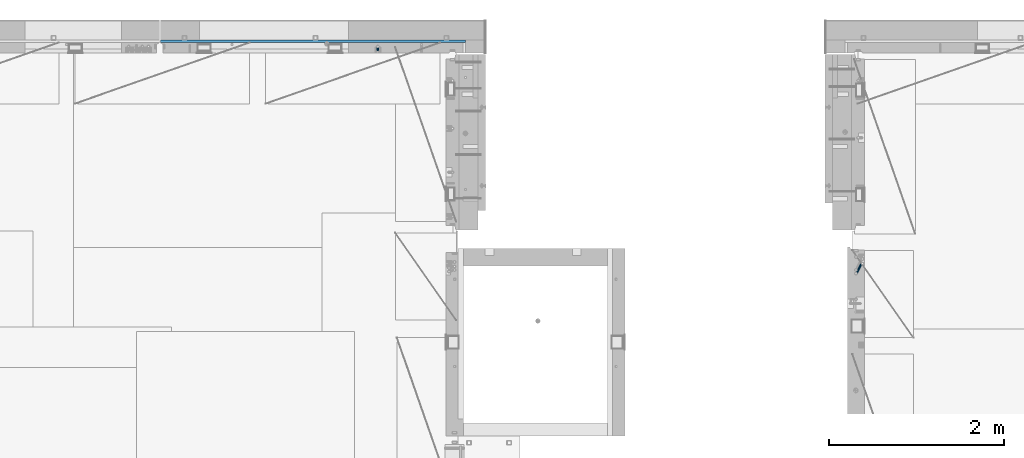
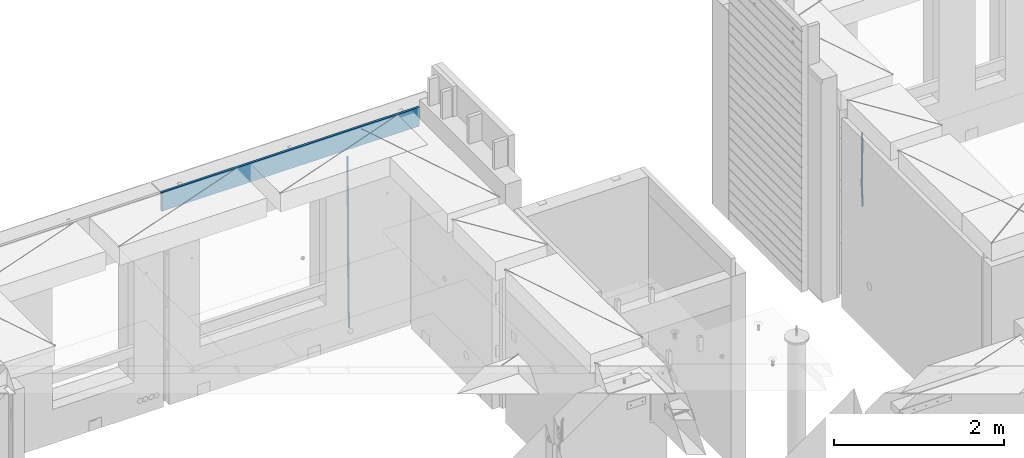
# One storey, part 105 of 309: 3 beams, 2 elements without a shape of their own.
"""IFC2X3 building model written with IfcOpenShell, lengths in millimetres."""

from ifc_helpers import new_model, si_unit, frame, origin_with_axes, place, context, subcontext, project, spatial, faceted_brep, material, type_object, element, aggregate, save


model = new_model("IFC2X3")

# Units and contexts
model_context = context("Model", 3, precision=1e-05, world=origin_with_axes())
body_context = subcontext(model_context, "Body", "Model", "MODEL_VIEW")
ifc_project = project(units=[si_unit("LENGTHUNIT", "METRE", prefix="MILLI"), si_unit("AREAUNIT", "SQUARE_METRE"), si_unit("VOLUMEUNIT", "CUBIC_METRE"), si_unit("MASSUNIT", "GRAM", prefix="KILO"), si_unit("TIMEUNIT", "SECOND"), si_unit("PLANEANGLEUNIT", "RADIAN"), si_unit("SOLIDANGLEUNIT", "STERADIAN"), si_unit("THERMODYNAMICTEMPERATUREUNIT", "DEGREE_CELSIUS"), si_unit("LUMINOUSINTENSITYUNIT", "LUMEN")], contexts=[model_context])

# Site, building, storey
site_placement = place(None, origin_with_axes())
site = spatial("IfcSite", under=ifc_project, at=site_placement, CompositionType="ELEMENT")
building_placement = place(site_placement, origin_with_axes())
building = spatial("IfcBuilding", under=site, at=building_placement, CompositionType="ELEMENT")
storey_placement = place(building_placement, origin_with_axes())
storey = spatial("IfcBuildingStorey", under=building, at=storey_placement, Name="7", CompositionType="ELEMENT", Elevation=0.0)

# Assembly, beam
assembly_1_placement = place(storey_placement, origin_with_axes())
assembly_1 = element("IfcElementAssembly", 1, at=assembly_1_placement, inside=storey, AssemblyPlace="NOTDEFINED", PredefinedType="REINFORCEMENT_UNIT")
ifc_material_1 = material()
beam_type_1 = type_object("IfcBeamType", Name="D20", PredefinedType="NOTDEFINED")
beam_1_placement = place(assembly_1_placement, frame((16830.0000000039, 22654.999995444, 99990.0), z_axis=(-0.000205762999925498, 0.999642804629538, -0.0267249099901004), x_axis=(4.30000201928125e-08, 0.0267249099948059, 0.999642825806181)))
beam_1 = element("IfcBeam", 2, at=beam_1_placement, type_object=beam_type_1, material=ifc_material_1, Name="JM20", ObjectType="D20", context=body_context, shape_type="Brep", body=[
    faceted_brep([(0.0, -10.0, 0.0), (-4.19531716033816e-08, -7.07106781186667, -7.07106781187031), (60.4266690400545, -7.0710677960451, -7.07106780570757), (60.4266690441291, -9.99999998418934, 6.15546014159918e-09), (0.0, 0.0, -10.0), (60.426669036824, 1.58106558956206e-08, -9.99999999384454), (4.196772351861e-08, 7.07106781186303, -7.07106781186667), (60.4266690363438, 7.07106782768096, -7.07106780570757), (0.0, 10.0, 0.0), (60.4266690388904, 10.0000000158179, 6.15182216279209e-09), (4.196772351861e-08, 7.07106781185939, 7.07106781185939), (60.4266690429649, 7.07106782768096, 7.07106781802577), (0.0, 0.0, 10.0), (60.4266690461809, 1.58179318532348e-08, 10.0000000061555), (-4.19531716033816e-08, -7.07106781187031, 7.07106781185939), (60.4266690466611, -7.07106779605238, 7.07106781802213), (61.0378400410118, -7.07106779588503, -7.07106780564936), (60.991799419251, -9.99999998403655, 6.21366780251265e-09), (61.0569027789461, 1.5985278878361e-08, -9.99999999378269), (61.0378209396877, 7.07106782784831, -7.07106780564936), (60.9917724058905, 10.0000000159635, 6.21366780251265e-09), (60.9457317841297, 7.07106782781193, 7.0710678180767), (60.9266690461809, 1.59488990902901e-08, 10.0000000062028), (60.9457508854539, -7.07106779591413, 7.0710678180767), (61.6489592143771, -7.07106614513759, -7.06310863441468), (61.5568818710308, -9.9999984576425, 0.00735959856683621), (61.6870830769039, 1.71821739058942e-06, -9.99179257185824), (61.6489210170112, 7.07106947854481, -7.06310888312146), (61.556827851804, 10.0000015422847, 0.00735924683976918), (61.4647505084577, 7.07106922979438, 7.07782747982128), (61.4266266459163, 1.36643211590126e-06, 10.0065114172685), (61.464788705809, -7.07106639389531, 7.07782772852806), (176.543135720174, -7.07075579406956, -5.56673531796696), (176.451058376813, -9.99968810657447, 1.50373291501455), (176.581259582701, 0.000312069292704109, -8.49541925541052), (176.543097522794, 7.07137982961285, -5.56673556667374), (176.451004357587, 10.00031189336, 1.50373256329476), (176.35892701424, 7.07137958085514, 8.57420079627263), (176.320803151699, 0.000311717507429421, 11.5028847337162), (176.358965211621, -7.07075604281999, 8.57420104497578), (177.098753836006, -7.07075429323595, -5.55949898843028), (176.98362511232, -9.99968666800123, 1.510669025065), (177.146421932586, 0.000313595905026887, -8.48805862247536), (177.098706077581, 7.07138133041735, -5.55949936166144), (176.983557571715, 10.0003133318824, 1.51066849724157), (176.868428848029, 7.07138095712435, 8.58083651073321), (176.820760751449, 0.000313067976094317, 11.5093961447819), (176.868476606425, -7.07075466652896, 8.58083688396073), (177.654312950661, -7.07075204110879, -5.54863964998367), (177.516135294456, -9.99968450931192, 1.52107783331303), (177.711524267797, 0.000315886711177882, -8.47701274570863), (177.654255632195, 7.07138358250813, -5.54864021007961), (177.516054233929, 10.0003154905207, 1.5210770412159), (177.377876577739, 7.0713830223176, 8.59079452451624), (177.320665260588, 0.000315094497636892, 11.5191676202448), (177.377933896176, -7.07075260129932, 8.59079508461218), (299.436796249574, -7.07025836271714, -3.1681962331204), (299.298618593355, -9.99919083092027, 3.90152125031091), (299.494007566798, 0.000809565110102994, -6.09656932889993), (299.436738931283, 7.07187726089978, -3.16819679320906), (299.298537533061, 10.0008091689197, 3.90152045822106), (299.160359876842, 7.07187670072017, 10.9712379416487), (299.103148559603, 0.000808772889286047, 13.8996110374392), (299.160417195119, -7.07025892290039, 10.9712385017483), (299.98743051647, -7.07025613056248, -3.15743315966392), (299.971788958996, -9.99918809853989, 3.91467979818117), (299.993912075952, 0.000811591617093654, -6.08679785393178), (299.987423933868, 7.07187949325817, -3.1574327280432), (299.971753863239, 10.0008119014747, 3.91467990454839), (299.95611230444, 7.07187992653053, 10.9867922621015), (299.949630744944, 0.000812204350950196, 13.9161569563694), (299.956118887014, -7.07025569729012, 10.9867918304735), (300.538107039494, -7.07025785017686, -3.16575821840888), (300.644985195438, -9.99919020432935, 3.90450175465594), (300.493854948218, 0.000810030429420294, -6.09435592770024), (300.538151196495, 7.071877773491, -3.16575855385963), (300.645047642858, 10.0008097955724, 3.90450128024895), (300.751925798773, 7.07187744142357, 10.9747612533101), (300.796177890064, 0.000809560813650023, 13.9033589625978), (300.751881641787, -7.07025818224065, 10.9747615887682), (2293.36490490142, -7.07648090940347, -33.2930642912361), (2293.47178305736, -10.0054132635523, -26.2228043181785), (2293.32065281013, -0.00541302880083094, -36.2216620005347), (2293.36494905842, 7.06565471425711, -33.2930646266868), (2293.47184550477, 9.99458673634581, -26.2228047925819), (2293.57872366071, 7.06565438219332, -19.1525448195243), (2293.62297575199, -0.00541349841296324, -16.2239471102366), (2293.57867950371, -7.0764812414709, -19.1525444840736), (2294.0658245362, -7.07648309818615, -33.3036607065333), (2294.05312277409, -10.0054150789219, -26.2315929392535), (2294.10928714235, -0.00541549149056664, -36.2335844756526), (2294.15805078732, 7.06565223761572, -33.3050546393533), (2294.18355038921, 9.99458451388637, -26.2335642579346), (2294.17084862708, 7.06565253314329, -19.1614964906439), (2294.12738602093, -0.00541507354500936, -16.2315727215355), (2294.07862237596, -7.07648280265857, -19.1601025578348), (2294.76670261032, -7.08562269121467, -33.294332712383), (2294.63442802057, -10.0129954178956, -26.2238563411993), (2294.89787471293, -0.0156988342423574, -36.2230891548279), (2294.95110548967, 7.05531064255774, -33.2944998654275), (2294.89521307347, 9.98530428734011, -26.2240927312887), (2294.76293848372, 7.0579315606592, -19.1536163601049), (2294.63176638114, -0.0119922963167483, -16.2248599176673), (2294.57853560438, -7.08300177311321, -19.1534492070678), (2316.52657204497, -7.36937582653991, -33.0047303660212), (2316.39429745522, -10.2967485532172, -25.9342539948302), (2316.65774414754, -0.299451969567599, -35.9334868084661), (2316.7109749243, 6.7715575072325, -33.0048975190657), (2316.65508250811, 9.70155115201487, -25.9344903849269), (2316.52280791836, 6.7741784253376, -18.8640140137468), (2316.39163581574, -0.295745431634714, -15.9352575713092), (2316.33840503903, -7.36675490843481, -18.863846860706), (2317.16202064224, -7.37766220584308, -32.9962731735213), (2317.05438744847, -10.3053562613532, -25.9254688497131), (2317.23607125619, -0.306993473008333, -35.925789846493), (2317.23316144495, 6.76474808850253, -32.9979477328052), (2317.15499573652, 9.6950321815566, -25.9278370341635), (2317.04736254275, 6.7673381260538, -18.8570327103698), (2316.97331192881, -0.303330606784584, -15.9275160373909), (2316.97622174003, -7.37507216829545, -18.8553581510787), (2317.79752306276, -7.37578610372293, -32.9880110666527), (2317.71453320107, -10.3033876998124, -25.9168792378296), (2317.81444760226, -0.305295583297266, -35.918287695793), (2317.75539265381, 6.76628640723357, -32.9911928173897), (2317.65495180529, 9.69652304524061, -25.9213789128698), (2317.5719619436, 6.76892144914746, -18.8502470840467), (2317.55503740412, -0.301569071270933, -15.9199704549137), (2317.61409235255, -7.3731510618054, -18.847065333317), (2417.8183084176, -7.07752398473531, -31.6906369377139), (2417.73531855589, -10.0051255808248, -24.6195051088798), (2417.83523295709, -0.007033464313281, -34.6209135668432), (2417.77617800863, 7.06454852621755, -31.6938186884508), (2417.67573716014, 9.99478516423187, -24.6240047839383), (2417.59274729842, 7.06718356813872, -17.5528729551006), (2417.57582275895, -0.00330695228694822, -14.6225963259749), (2417.6348777074, -7.07488894281778, -17.5496912043673)], [[[0, 1, 2, 3]], [[1, 4, 5, 2]], [[4, 6, 7, 5]], [[6, 8, 9, 7]], [[8, 10, 11, 9]], [[10, 12, 13, 11]], [[12, 14, 15, 13]], [[14, 0, 3, 15]], [[14, 12, 10, 8, 6, 4, 1, 0]], [[3, 2, 16, 17]], [[2, 5, 18, 16]], [[5, 7, 19, 18]], [[7, 9, 20, 19]], [[9, 11, 21, 20]], [[11, 13, 22, 21]], [[13, 15, 23, 22]], [[15, 3, 17, 23]], [[17, 16, 24, 25]], [[16, 18, 26, 24]], [[18, 19, 27, 26]], [[19, 20, 28, 27]], [[20, 21, 29, 28]], [[21, 22, 30, 29]], [[22, 23, 31, 30]], [[23, 17, 25, 31]], [[25, 24, 32, 33]], [[24, 26, 34, 32]], [[26, 27, 35, 34]], [[27, 28, 36, 35]], [[28, 29, 37, 36]], [[29, 30, 38, 37]], [[30, 31, 39, 38]], [[31, 25, 33, 39]], [[33, 32, 40, 41]], [[32, 34, 42, 40]], [[34, 35, 43, 42]], [[35, 36, 44, 43]], [[36, 37, 45, 44]], [[37, 38, 46, 45]], [[38, 39, 47, 46]], [[39, 33, 41, 47]], [[41, 40, 48, 49]], [[40, 42, 50, 48]], [[42, 43, 51, 50]], [[43, 44, 52, 51]], [[44, 45, 53, 52]], [[45, 46, 54, 53]], [[46, 47, 55, 54]], [[47, 41, 49, 55]], [[49, 48, 56, 57]], [[48, 50, 58, 56]], [[50, 51, 59, 58]], [[51, 52, 60, 59]], [[52, 53, 61, 60]], [[53, 54, 62, 61]], [[54, 55, 63, 62]], [[55, 49, 57, 63]], [[57, 56, 64, 65]], [[56, 58, 66, 64]], [[58, 59, 67, 66]], [[59, 60, 68, 67]], [[60, 61, 69, 68]], [[61, 62, 70, 69]], [[62, 63, 71, 70]], [[63, 57, 65, 71]], [[65, 64, 72, 73]], [[64, 66, 74, 72]], [[66, 67, 75, 74]], [[67, 68, 76, 75]], [[68, 69, 77, 76]], [[69, 70, 78, 77]], [[70, 71, 79, 78]], [[71, 65, 73, 79]], [[73, 72, 80, 81]], [[72, 74, 82, 80]], [[74, 75, 83, 82]], [[75, 76, 84, 83]], [[76, 77, 85, 84]], [[77, 78, 86, 85]], [[78, 79, 87, 86]], [[79, 73, 81, 87]], [[81, 80, 88, 89]], [[80, 82, 90, 88]], [[82, 83, 91, 90]], [[83, 84, 92, 91]], [[84, 85, 93, 92]], [[85, 86, 94, 93]], [[86, 87, 95, 94]], [[87, 81, 89, 95]], [[89, 88, 96, 97]], [[88, 90, 98, 96]], [[90, 91, 99, 98]], [[91, 92, 100, 99]], [[92, 93, 101, 100]], [[93, 94, 102, 101]], [[94, 95, 103, 102]], [[95, 89, 97, 103]], [[97, 96, 104, 105]], [[96, 98, 106, 104]], [[98, 99, 107, 106]], [[99, 100, 108, 107]], [[100, 101, 109, 108]], [[101, 102, 110, 109]], [[102, 103, 111, 110]], [[103, 97, 105, 111]], [[105, 104, 112, 113]], [[104, 106, 114, 112]], [[106, 107, 115, 114]], [[107, 108, 116, 115]], [[108, 109, 117, 116]], [[109, 110, 118, 117]], [[110, 111, 119, 118]], [[111, 105, 113, 119]], [[113, 112, 120, 121]], [[112, 114, 122, 120]], [[114, 115, 123, 122]], [[115, 116, 124, 123]], [[116, 117, 125, 124]], [[117, 118, 126, 125]], [[118, 119, 127, 126]], [[119, 113, 121, 127]], [[121, 120, 128, 129]], [[120, 122, 130, 128]], [[122, 123, 131, 130]], [[123, 124, 132, 131]], [[124, 125, 133, 132]], [[125, 126, 134, 133]], [[126, 127, 135, 134]], [[127, 121, 129, 135]], [[130, 131, 132, 133, 134, 135, 129, 128]]]),
])

assembly_2_placement = place(storey_placement, origin_with_axes())
assembly_2 = element("IfcElementAssembly", 3, at=assembly_2_placement, inside=storey, Name="W1", AssemblyPlace="NOTDEFINED", PredefinedType="REINFORCEMENT_UNIT")
beam_2_placement = place(assembly_2_placement, frame((22385.0000022791, 20210.0000000039, 101267.5), z_axis=(-0.999642804636942, -0.000205726999925762, -0.0267249099902983), x_axis=(-0.0267249099948371, 4.30000201934385e-08, 0.999642825806181)))
beam_2 = element("IfcBeam", 4, at=beam_2_placement, type_object=beam_type_1, material=ifc_material_1, Name="JM20", ObjectType="D20", context=body_context, shape_type="Brep", body=[
    faceted_brep([(0.0, -10.0, 0.0), (-4.19531716033816e-08, -7.07106781186667, -7.07106781187031), (60.4266690400545, -7.0710677960451, -7.07106780570757), (60.4266690441291, -9.99999998418934, 6.15546014159918e-09), (0.0, 0.0, -10.0), (60.426669036824, 1.58106558956206e-08, -9.99999999384454), (4.196772351861e-08, 7.07106781186303, -7.07106781186667), (60.4266690363438, 7.07106782768096, -7.07106780570757), (0.0, 10.0, 0.0), (60.4266690388904, 10.0000000158179, 6.15182216279209e-09), (4.196772351861e-08, 7.07106781185939, 7.07106781185939), (60.4266690429649, 7.07106782768096, 7.07106781802577), (0.0, 0.0, 10.0), (60.4266690461809, 1.58179318532348e-08, 10.0000000061555), (-4.19531716033816e-08, -7.07106781187031, 7.07106781185939), (60.4266690466611, -7.07106779605238, 7.07106781802213), (61.0378400410118, -7.07106779588503, -7.07106780564936), (60.991799419251, -9.99999998403655, 6.21366780251265e-09), (61.0569027789461, 1.5985278878361e-08, -9.99999999378269), (61.0378209396877, 7.07106782784831, -7.07106780564936), (60.9917724058905, 10.0000000159635, 6.21366780251265e-09), (60.9457317841297, 7.07106782781193, 7.0710678180767), (60.9266690461809, 1.59488990902901e-08, 10.0000000062028), (60.9457508854539, -7.07106779591413, 7.0710678180767), (61.6489592143771, -7.07106614513759, -7.06310863441468), (61.5568818710308, -9.9999984576425, 0.00735959856683621), (61.6870830769039, 1.71821739058942e-06, -9.99179257185824), (61.6489210170112, 7.07106947854481, -7.06310888312146), (61.556827851804, 10.0000015422847, 0.00735924683976918), (61.4647505084577, 7.07106922979438, 7.07782747982128), (61.4266266459163, 1.36643211590126e-06, 10.0065114172685), (61.464788705809, -7.07106639389531, 7.07782772852806), (176.543135720174, -7.07075579406956, -5.56673531796696), (176.451058376813, -9.99968810657447, 1.50373291501455), (176.581259582701, 0.000312069292704109, -8.49541925541052), (176.543097522794, 7.07137982961285, -5.56673556667374), (176.451004357587, 10.00031189336, 1.50373256329476), (176.35892701424, 7.07137958085514, 8.57420079627263), (176.320803151699, 0.000311717507429421, 11.5028847337162), (176.358965211621, -7.07075604281999, 8.57420104497578), (177.098753836006, -7.07075429323595, -5.55949898843028), (176.98362511232, -9.99968666800123, 1.510669025065), (177.146421932586, 0.000313595905026887, -8.48805862247536), (177.098706077581, 7.07138133041735, -5.55949936166144), (176.983557571715, 10.0003133318824, 1.51066849724157), (176.868428848029, 7.07138095712435, 8.58083651073321), (176.820760751449, 0.000313067976094317, 11.5093961447819), (176.868476606425, -7.07075466652896, 8.58083688396073), (177.654312950661, -7.07075204110879, -5.54863964998367), (177.516135294456, -9.99968450931192, 1.52107783331303), (177.711524267797, 0.000315886711177882, -8.47701274570863), (177.654255632195, 7.07138358250813, -5.54864021007961), (177.516054233929, 10.0003154905207, 1.5210770412159), (177.377876577739, 7.0713830223176, 8.59079452451624), (177.320665260588, 0.000315094497636892, 11.5191676202448), (177.377933896176, -7.07075260129932, 8.59079508461218), (298.815467493725, -7.07026087564373, -3.18034085036197), (298.677289837564, -9.99919334385049, 3.88937663293109), (298.872678810818, 0.000807052179879975, -6.10871394609057), (298.815410175172, 7.07187474796592, -3.18034141045791), (298.677208776877, 10.0008066559858, 3.8893758408376), (298.539031120687, 7.07187418777903, 10.9590933241343), (298.481819803608, 0.000806259959063027, 13.8874664198629), (298.539088439255, -7.07026143583425, 10.9590938842302), (299.67009200262, -7.07025741116013, -3.16363577515585), (299.177194346703, -9.99919131733259, 3.89914810839764), (300.339709364547, 0.00081299923840561, -6.08003836345233), (300.79379366347, 7.07188276795205, -3.141670573601), (300.766348475532, 10.0008151249531, 3.9302115943392), (300.273450819615, 7.07188121878789, 10.9929954778927), (299.603833457673, 0.000810808385722339, 13.9093980661892), (299.14974915878, -7.07025896033156, 10.9710302763342), (300.512913202241, -7.2052330304432, -3.11785238911762), (299.67019462194, -10.0781440269784, 3.92592866628183), (301.78647860451, -0.230883325217292, -6.00144756073496), (302.74485348865, 6.7594256201337, -3.03568590543364), (302.826634845376, 9.67086563057819, 4.04212962187376), (301.983916265046, 6.79795463404662, 11.0859106772696), (300.710350862806, -0.1763950711902, 13.9695058488869), (299.751975978652, -7.16670401652664, 11.0037441935892), (1016.06255465306, -121.798643856979, 35.7519404949198), (1015.21983607276, -124.67155485351, 42.7957215503156), (1017.33612005532, -114.824294151749, 32.8683453233025), (1018.29449493947, -107.833985206405, 35.8341069786038), (1018.3762762962, -104.922545195961, 42.9119225059112), (1017.5335577159, -107.795456192489, 49.955703561307), (1016.25999231363, -114.769805897726, 52.8392987329207), (1015.30161742949, -121.760114843066, 49.873537077623), (1017.64070561952, -122.051380622637, 35.8376681616683), (1017.15071056716, -124.980779373207, 42.9006097192614), (1018.3470245444, -114.986187871924, 32.9232592605622), (1018.85591529503, -107.923895213658, 35.8646042239052), (1018.86927657142, -105.001497905603, 42.9387030637918), (1018.37928151908, -107.930896656177, 50.0016446213813), (1017.67296259418, -114.996089406886, 52.9160535224946), (1017.16407184357, -122.058382065152, 49.974708559148), (1019.2409857497, -122.072248321667, 35.8589665747968), (1019.10866018859, -125.006311092715, 42.9266684193208), (1019.37210414821, -114.99955493951, 32.9369022274914), (1019.42520800454, -107.931318807005, 35.8721810419192), (1019.36918979988, -105.008016788513, 42.9453564979449), (1019.23686423877, -107.942079559562, 50.0130583424689), (1019.10574584025, -115.014772941722, 52.9351226897743), (1019.05264198393, -122.083009074224, 49.9998438753428), (1040.41841028637, -122.348402548138, 36.140820687895), (1040.28608472526, -125.282465319182, 43.2085225324154), (1040.54952868487, -115.275709165981, 33.2187563405823), (1040.60263254121, -108.207473033472, 36.1540351550175), (1040.54661433655, -105.284171014984, 43.2272106110395), (1040.41428877544, -108.218233786029, 50.2949124555635), (1040.28317037692, -115.290927168189, 53.2169768028689), (1040.2300665206, -122.359163300694, 50.281697988441), (1041.05380050941, -122.356688054962, 36.1492772094862), (1040.9461697993, -125.291072847573, 43.2173077221705), (1041.12777671829, -115.283249537002, 33.2264523466038), (1041.12476416609, -108.214281644912, 36.1609842977596), (1041.04652756499, -105.290689897894, 43.233864045189), (1040.93889685487, -108.225074690508, 50.3018945578842), (1040.864920646, -115.298513208465, 53.224719420763), (1040.86793319821, -122.367481100559, 50.2901874695999), (1041.68924454234, -122.354813008245, 36.1575394084866), (1041.60631061636, -125.289104322157, 43.2258984974833), (1041.7060739864, -115.281553105524, 33.2339534458297), (1041.64694048846, -108.212744334829, 36.1677376156767), (1041.54648364961, -105.289199004201, 43.2403209404038), (1041.4635497236, -108.22349031812, 50.3086800294004), (1041.44672027956, -115.296750220841, 53.2322659920574), (1041.50585377749, -122.365558991532, 50.2984818222067), (1141.71003235725, -122.056550144174, 37.4549136692622), (1141.62709843126, -124.990841458086, 44.5232727582552), (1141.72686180132, -114.983290241453, 34.5313277066016), (1141.66772830336, -107.914481470762, 37.4651118764486), (1141.56727146452, -104.99093614013, 44.5376952011684), (1141.48433753852, -107.925227454049, 51.6060542901723), (1141.46750809446, -114.99848735677, 54.5296402528293), (1141.52664159241, -122.067296127461, 51.5958560829858)], [[[0, 1, 2, 3]], [[1, 4, 5, 2]], [[4, 6, 7, 5]], [[6, 8, 9, 7]], [[8, 10, 11, 9]], [[10, 12, 13, 11]], [[12, 14, 15, 13]], [[14, 0, 3, 15]], [[14, 12, 10, 8, 6, 4, 1, 0]], [[3, 2, 16, 17]], [[2, 5, 18, 16]], [[5, 7, 19, 18]], [[7, 9, 20, 19]], [[9, 11, 21, 20]], [[11, 13, 22, 21]], [[13, 15, 23, 22]], [[15, 3, 17, 23]], [[17, 16, 24, 25]], [[16, 18, 26, 24]], [[18, 19, 27, 26]], [[19, 20, 28, 27]], [[20, 21, 29, 28]], [[21, 22, 30, 29]], [[22, 23, 31, 30]], [[23, 17, 25, 31]], [[25, 24, 32, 33]], [[24, 26, 34, 32]], [[26, 27, 35, 34]], [[27, 28, 36, 35]], [[28, 29, 37, 36]], [[29, 30, 38, 37]], [[30, 31, 39, 38]], [[31, 25, 33, 39]], [[33, 32, 40, 41]], [[32, 34, 42, 40]], [[34, 35, 43, 42]], [[35, 36, 44, 43]], [[36, 37, 45, 44]], [[37, 38, 46, 45]], [[38, 39, 47, 46]], [[39, 33, 41, 47]], [[41, 40, 48, 49]], [[40, 42, 50, 48]], [[42, 43, 51, 50]], [[43, 44, 52, 51]], [[44, 45, 53, 52]], [[45, 46, 54, 53]], [[46, 47, 55, 54]], [[47, 41, 49, 55]], [[49, 48, 56, 57]], [[48, 50, 58, 56]], [[50, 51, 59, 58]], [[51, 52, 60, 59]], [[52, 53, 61, 60]], [[53, 54, 62, 61]], [[54, 55, 63, 62]], [[55, 49, 57, 63]], [[57, 56, 64, 65]], [[56, 58, 66, 64]], [[58, 59, 67, 66]], [[59, 60, 68, 67]], [[60, 61, 69, 68]], [[61, 62, 70, 69]], [[62, 63, 71, 70]], [[63, 57, 65, 71]], [[65, 64, 72, 73]], [[64, 66, 74, 72]], [[66, 67, 75, 74]], [[67, 68, 76, 75]], [[68, 69, 77, 76]], [[69, 70, 78, 77]], [[70, 71, 79, 78]], [[71, 65, 73, 79]], [[73, 72, 80, 81]], [[72, 74, 82, 80]], [[74, 75, 83, 82]], [[75, 76, 84, 83]], [[76, 77, 85, 84]], [[77, 78, 86, 85]], [[78, 79, 87, 86]], [[79, 73, 81, 87]], [[81, 80, 88, 89]], [[80, 82, 90, 88]], [[82, 83, 91, 90]], [[83, 84, 92, 91]], [[84, 85, 93, 92]], [[85, 86, 94, 93]], [[86, 87, 95, 94]], [[87, 81, 89, 95]], [[89, 88, 96, 97]], [[88, 90, 98, 96]], [[90, 91, 99, 98]], [[91, 92, 100, 99]], [[92, 93, 101, 100]], [[93, 94, 102, 101]], [[94, 95, 103, 102]], [[95, 89, 97, 103]], [[97, 96, 104, 105]], [[96, 98, 106, 104]], [[98, 99, 107, 106]], [[99, 100, 108, 107]], [[100, 101, 109, 108]], [[101, 102, 110, 109]], [[102, 103, 111, 110]], [[103, 97, 105, 111]], [[105, 104, 112, 113]], [[104, 106, 114, 112]], [[106, 107, 115, 114]], [[107, 108, 116, 115]], [[108, 109, 117, 116]], [[109, 110, 118, 117]], [[110, 111, 119, 118]], [[111, 105, 113, 119]], [[113, 112, 120, 121]], [[112, 114, 122, 120]], [[114, 115, 123, 122]], [[115, 116, 124, 123]], [[116, 117, 125, 124]], [[117, 118, 126, 125]], [[118, 119, 127, 126]], [[119, 113, 121, 127]], [[121, 120, 128, 129]], [[120, 122, 130, 128]], [[122, 123, 131, 130]], [[123, 124, 132, 131]], [[124, 125, 133, 132]], [[125, 126, 134, 133]], [[126, 127, 135, 134]], [[127, 121, 129, 135]], [[130, 131, 132, 133, 134, 135, 129, 128]]]),
])
aggregate(assembly_2, [beam_2])

# Beam
ifc_material_2 = material(Name="CONCRETE/C25/30")
beam_type_2 = type_object("IfcBeamType", Name="270X30", PredefinedType="NOTDEFINED")
beam_3_placement = place(assembly_1_placement, frame((17835.0, 22755.0, 102605.0), z_axis=(0.0, 0.0, 1.0), x_axis=(-1.0, 3.00000001838171e-08, 0.0)))
beam_3 = element("IfcBeam", 5, at=beam_3_placement, type_object=beam_type_2, material=ifc_material_2, ObjectType="270X30", context=body_context, shape_type="Brep", body=[
    faceted_brep([(0.0, 15.0, -135.0), (0.0, 15.0, 135.0), (3495.00000000002, 15.0, 135.0), (3495.00000000002, 15.0, -135.0), (0.0, -15.0, 135.0), (3495.00000000002, -15.0, 135.0), (0.0, -15.0, -135.0), (3495.00000000002, -15.0, -135.0)], [[[0, 1, 2, 3]], [[1, 4, 5, 2]], [[4, 6, 7, 5]], [[6, 0, 3, 7]], [[5, 7, 3, 2]], [[6, 4, 1, 0]]]),
])

aggregate(assembly_1, [beam_1, beam_3])

save(model, "model.ifc")
